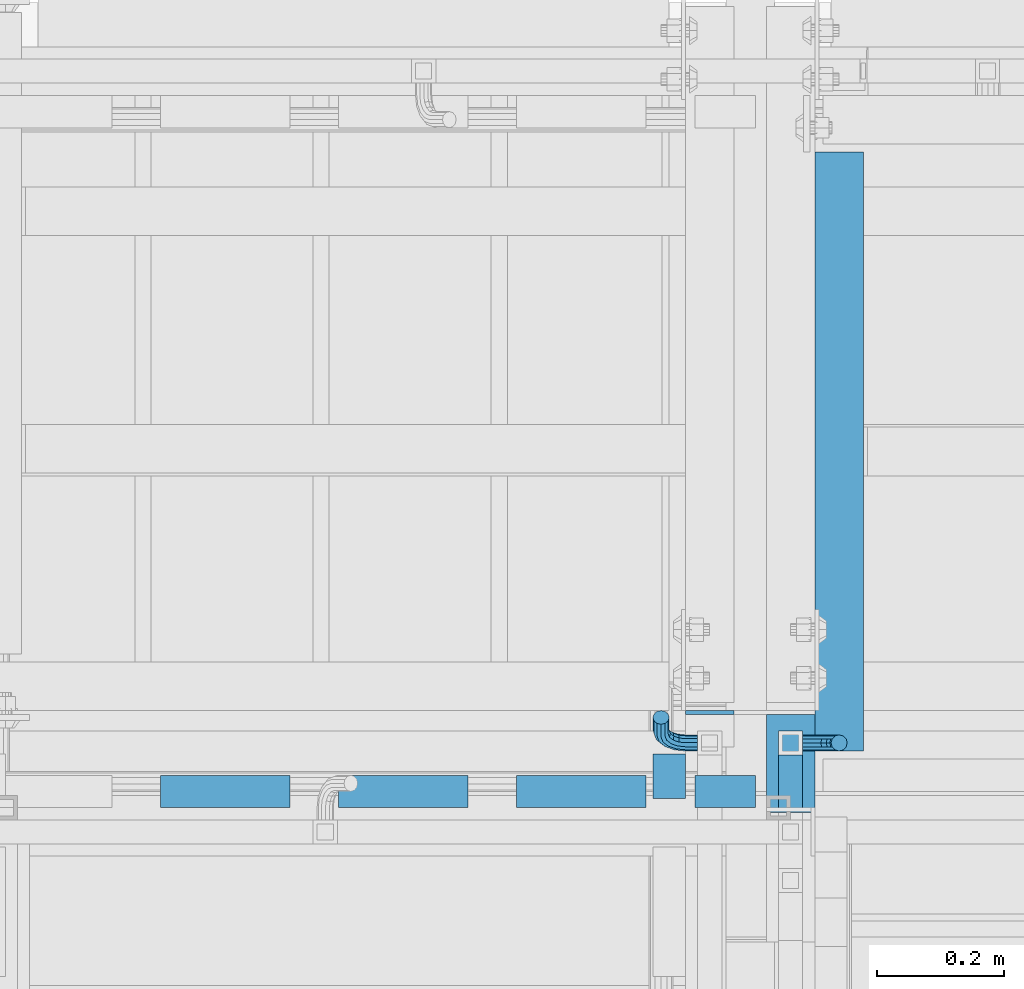
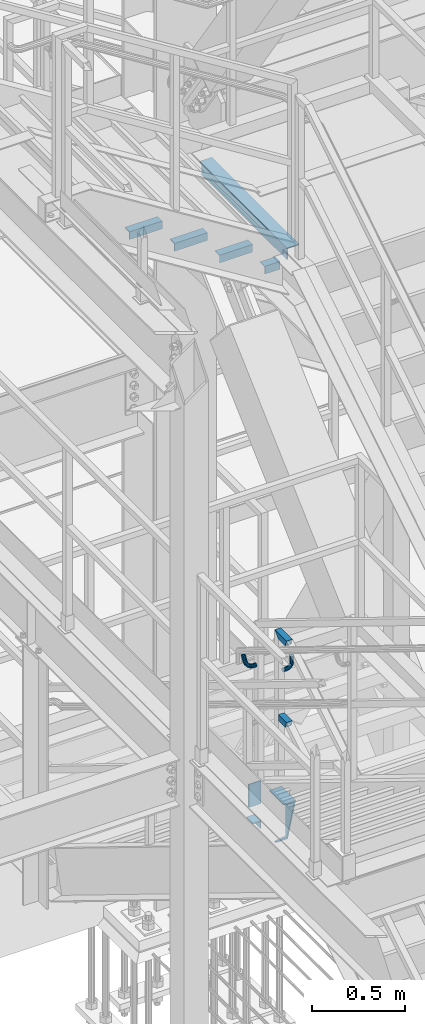
# One storey, part 2097 of 3843: 12 beams, 6 elements without a shape of their own.
"""IFC2X3 building model written with IfcOpenShell, lengths in millimetres."""

from ifc_helpers import new_model, si_unit, frame, origin_with_axes, place, context, subcontext, project, spatial, faceted_brep, material, type_object, element, aggregate, save


model = new_model("IFC2X3")

# Units and contexts
model_context = context("Model", 3, precision=1e-05, world=origin_with_axes())
body_context = subcontext(model_context, "Body", "Model", "MODEL_VIEW")
ifc_project = project(units=[si_unit("LENGTHUNIT", "METRE", prefix="MILLI"), si_unit("AREAUNIT", "SQUARE_METRE"), si_unit("VOLUMEUNIT", "CUBIC_METRE"), si_unit("MASSUNIT", "GRAM", prefix="KILO"), si_unit("TIMEUNIT", "SECOND"), si_unit("PLANEANGLEUNIT", "RADIAN"), si_unit("SOLIDANGLEUNIT", "STERADIAN"), si_unit("THERMODYNAMICTEMPERATUREUNIT", "DEGREE_CELSIUS"), si_unit("LUMINOUSINTENSITYUNIT", "LUMEN")], contexts=[model_context])

# Site, building, storey
site_placement = place(None, origin_with_axes())
site = spatial("IfcSite", under=ifc_project, at=site_placement, CompositionType="ELEMENT")
building_placement = place(site_placement, origin_with_axes())
building = spatial("IfcBuilding", under=site, at=building_placement, Name="Undefined", CompositionType="ELEMENT")
storey_placement = place(building_placement, origin_with_axes())
storey = spatial("IfcBuildingStorey", under=building, at=storey_placement, Name="Undefined", CompositionType="ELEMENT", Elevation=0.0)

# Assembly, beams
assembly_1_placement = place(storey_placement, origin_with_axes())
assembly_1 = element("IfcElementAssembly", 1, at=assembly_1_placement, inside=storey, Name="RAIL", AssemblyPlace="NOTDEFINED", PredefinedType="RIGID_FRAME")
ifc_material_1 = material()
beam_type_1 = type_object("IfcBeamType", Name="HSS1-1/2X1-1/2X1/4", PredefinedType="NOTDEFINED")
beam_1_placement = place(assembly_1_placement, frame((54444.9, 21755.1000004853, 33592.4769212995), z_axis=(0.0, 0.0, 1.0), x_axis=(0.0, 1.0, 0.0)))
beam_1 = element("IfcBeam", 2, at=beam_1_placement, type_object=beam_type_1, material=ifc_material_1, Name="RAIL", ObjectType="HSS1-1/2X1-1/2X1/4", context=body_context, shape_type="Brep", body=[
    faceted_brep([(3.59463564452017, 12.6999993300014, -12.6999993299978), (3.59463564452017, -12.6999993300014, -12.6999993299978), (82.5500000532629, -12.6999993300014, -12.6999993299978), (82.5500000532629, 12.6999993300014, -12.6999993299978), (-3.59463560431323, -12.6999993300014, 12.6999993299978), (82.5500000532629, -12.6999993300014, 12.6999993299978), (-3.59463560431323, 12.6999993300014, 12.6999993299978), (82.5500000532629, 12.6999993300014, 12.6999993299978), (5.39195352466777, 19.0499992350015, -19.0499992350015), (-5.39195348444628, 19.0499992350015, 19.0499992350015), (82.5500000532629, 19.0499992350015, 19.0499992350015), (82.5500000532629, 19.0499992350015, -19.0499992350015), (-5.39195348444628, -19.0499992350015, 19.0499992350015), (82.5500000532629, -19.0499999999993, 19.0499992350015), (5.39195352466777, -19.0499992350015, -19.0499992350015), (82.5500000532629, -19.0499992350015, -19.0499992350015)], [[[0, 1, 2, 3]], [[1, 4, 5, 2]], [[4, 6, 7, 5]], [[6, 0, 3, 7]], [[8, 9, 10, 11]], [[9, 12, 13, 10]], [[12, 14, 15, 13]], [[14, 8, 11, 15]], [[13, 15, 11, 10], [5, 7, 3, 2]], [[14, 12, 9, 8], [6, 4, 1, 0]]]),
])
beam_2_placement = place(assembly_1_placement, frame((54444.9, 21856.7000000145, 34125.8769212988), z_axis=(0.0, 0.0, -1.0), x_axis=(0.0, -1.0, 0.0)))
beam_2 = element("IfcBeam", 3, at=beam_2_placement, type_object=beam_type_1, material=ifc_material_1, Name="RAIL", ObjectType="HSS1-1/2X1-1/2X1/4", context=body_context, shape_type="Brep", body=[
    faceted_brep([(-12.6999993309546, 12.6999993299978, -12.6999993299978), (-12.6999993309546, -12.6999993299978, -12.6999993299978), (105.194632755753, -12.6999993299978, -12.6999993299978), (105.194632755753, 12.6999993299978, -12.6999993299978), (12.6999993290483, -12.6999993299978, 12.6999993299978), (98.0053615143879, -12.6999993299978, 12.6999993299978), (12.6999993290483, 12.6999993299978, 12.6999993299978), (98.0053615143879, 12.6999993299978, 12.6999993299978), (-19.0499992359546, 19.0499992350015, -19.0499992350015), (19.0499992350015, 19.0499992350015, 19.0499992350015), (96.2080436361175, 19.0499992350015, 19.0499992350015), (106.991950634023, 19.0499992350015, -19.0499992350015), (19.0499992350015, -19.0499992350015, 19.0499992350015), (96.2080436361175, -19.0499992350015, 19.0499992350015), (-19.0499992359546, -19.0499992350015, -19.0499992350015), (106.991950634023, -19.0499992350015, -19.0499992350015)], [[[0, 1, 2, 3]], [[1, 4, 5, 2]], [[4, 6, 7, 5]], [[6, 0, 3, 7]], [[8, 9, 10, 11]], [[9, 12, 13, 10]], [[12, 14, 15, 13]], [[14, 8, 11, 15]], [[13, 15, 11, 10], [5, 7, 3, 2]], [[14, 12, 9, 8], [6, 4, 1, 0]]]),
])

# Assembly, beam
assembly_2_placement = place(storey_placement, origin_with_axes())
assembly_2 = element("IfcElementAssembly", 4, at=assembly_2_placement, inside=storey, Name="STAIR", AssemblyPlace="NOTDEFINED", PredefinedType="RIGID_FRAME")
ifc_material_2 = material(Name="STEEL/A36")
beam_type_2 = type_object("IfcBeamType", PredefinedType="NOTDEFINED")
beam_3_placement = place(assembly_2_placement, frame((54317.9000000233, 21904.3250000033, 33164.6126284988), z_axis=(-1.0, 0.0, 0.0), x_axis=(0.0, 0.0, -1.0)))
beam_3 = element("IfcBeam", 5, at=beam_3_placement, type_object=beam_type_2, material=ifc_material_2, Name="PLATE", context=body_context, shape_type="Brep", body=[
    faceted_brep([(0.0, 3.17500000000291, -38.0999999999985), (0.0, 3.17500000000291, 38.0999999999985), (149.985707179992, 3.17499999999927, 38.0999999999985), (149.985707179992, 3.17499999999927, -38.0999999999985), (0.0, -3.17500000000291, 38.0999999999985), (149.985707179992, -3.17499999999927, 38.0999999999985), (0.0, -3.17500000000291, -38.0999999999985), (149.985707179992, -3.17499999999927, -38.0999999999985)], [[[0, 1, 2, 3]], [[1, 4, 5, 2]], [[4, 6, 7, 5]], [[6, 0, 3, 7]], [[5, 7, 3, 2]], [[6, 4, 1, 0]]]),
])

assembly_3_placement = place(storey_placement, origin_with_axes())
assembly_3 = element("IfcElementAssembly", 6, at=assembly_3_placement, inside=storey, Name="STAIR", AssemblyPlace="NOTDEFINED", PredefinedType="RIGID_FRAME")
beam_type_3 = type_object("IfcBeamType", Name="L2X2X3/16", PredefinedType="NOTDEFINED")
beam_4_placement = place(assembly_3_placement, frame((54389.8434500262, 21780.5000000956, 36618.3200647408), z_axis=(0.0, 1.0, 0.0), x_axis=(-1.0, 0.0, 0.0)))
beam_4 = element("IfcBeam", 7, at=beam_4_placement, type_object=beam_type_3, material=ifc_material_2, Name="ANGLE", ObjectType="L2X2X3/16", context=body_context, shape_type="Brep", body=[
    faceted_brep([(0.0, 25.4000000000015, -25.4000000000015), (0.0, 25.4000000000015, 25.4000000000015), (95.25, 25.4000000000015, 25.4000000000015), (95.25, 25.4000000000015, -25.4000000000015), (0.0, 20.6375000000007, 25.4000000000015), (95.25, 20.6374999999971, 25.4000000000015), (0.0, 20.6375000000007, -20.6375000000007), (95.25, 20.6374999999971, -20.6375000000007), (0.0, -25.4000000000015, -20.6375000000007), (95.25, -25.4000000000015, -20.6375000000007), (0.0, -25.4000000000015, -25.4000000000015), (95.25, -25.4000000000015, -25.4000000000015)], [[[0, 1, 2, 3]], [[1, 4, 5, 2]], [[4, 6, 7, 5]], [[6, 8, 9, 7]], [[8, 10, 11, 9]], [[10, 0, 3, 11]], [[5, 7, 9, 11, 3, 2]], [[10, 8, 6, 4, 1, 0]]]),
])

# Beam
beam_5_placement = place(assembly_2_placement, frame((54254.4000000118, 21839.6359969497, 32982.8769213407), z_axis=(-1.0, 0.0, 0.0), x_axis=(0.0, -1.0, 0.0)))
beam_5 = element("IfcBeam", 8, at=beam_5_placement, type_object=beam_type_3, material=ifc_material_2, Name="ANGLE", ObjectType="L2X2X3/16", context=body_context, shape_type="Brep", body=[
    faceted_brep([(0.0, 25.4000000000015, -25.4000000000015), (0.0, 25.4000000000015, 25.4000000000015), (69.8499999999985, 25.4000000000015, 25.4000000000015), (69.8499999999985, 25.4000000000015, -25.4000000000015), (0.0, 20.6375000000007, 25.4000000000015), (69.8499999999985, 20.6374999999971, 25.4000000000015), (0.0, 20.6375000000007, -20.6375000000007), (69.8499999999985, 20.6374999999971, -20.6374999999971), (0.0, -25.4000000000015, -20.6375000000007), (69.8499999999985, -25.4000000000015, -20.6374999999971), (0.0, -25.4000000000015, -25.4000000000015), (69.8499999999985, -25.4000000000015, -25.4000000000015)], [[[0, 1, 2, 3]], [[1, 4, 5, 2]], [[4, 6, 7, 5]], [[6, 8, 9, 7]], [[8, 10, 11, 9]], [[10, 0, 3, 11]], [[5, 7, 9, 11, 3, 2]], [[10, 8, 6, 4, 1, 0]]]),
])

aggregate(assembly_2, [beam_5, beam_3])

ifc_material_3 = material(Name="STEEL/A572-50")
beam_6_placement = place(assembly_3_placement, frame((53659.5934500424, 21780.5000000971, 37138.3983316133), z_axis=(0.0, 1.0, 0.0), x_axis=(-1.0, 0.0, 0.0)))
beam_6 = element("IfcBeam", 9, at=beam_6_placement, type_object=beam_type_3, material=ifc_material_3, Name="ANGLE", ObjectType="L2X2X3/16", context=body_context, shape_type="Brep", body=[
    faceted_brep([(0.0, 25.4000000000015, -25.4000000000015), (0.0, 25.4000000000015, 25.4000000000015), (203.199999999997, 25.4000000000015, 25.4000000000015), (203.199999999997, 25.4000000000015, -25.4000000000015), (0.0, 20.6375000000007, 25.4000000000015), (203.199999999997, 20.6375000000007, 25.4000000000015), (0.0, 20.6375000000007, -20.6375000000007), (203.199999999997, 20.6375000000007, -20.6375000000007), (0.0, -25.4000000000015, -20.6375000000007), (203.199999999997, -25.4000000000015, -20.6375000000007), (0.0, -25.4000000000015, -25.4000000000015), (203.199999999997, -25.4000000000015, -25.4000000000015)], [[[0, 1, 2, 3]], [[1, 4, 5, 2]], [[4, 6, 7, 5]], [[6, 8, 9, 7]], [[8, 10, 11, 9]], [[10, 0, 3, 11]], [[5, 7, 9, 11, 3, 2]], [[10, 8, 6, 4, 1, 0]]]),
])

beam_7_placement = place(assembly_3_placement, frame((53938.9934500395, 21780.5000000963, 36963.9849981713), z_axis=(0.0, 1.0, 0.0), x_axis=(-1.0, 0.0, 0.0)))
beam_7 = element("IfcBeam", 10, at=beam_7_placement, type_object=beam_type_3, material=ifc_material_3, Name="ANGLE", ObjectType="L2X2X3/16", context=body_context, shape_type="Brep", body=[
    faceted_brep([(0.0, 25.4000000000015, -25.4000000000015), (0.0, 25.4000000000015, 25.4000000000015), (203.199999999997, 25.4000000000015, 25.4000000000015), (203.199999999997, 25.4000000000015, -25.4000000000015), (0.0, 20.6375000000007, 25.4000000000015), (203.199999999997, 20.6375000000007, 25.4000000000015), (0.0, 20.6375000000007, -20.6375000000007), (203.199999999997, 20.6375000000007, -20.6375000000007), (0.0, -25.4000000000015, -20.6375000000007), (203.199999999997, -25.4000000000015, -20.6375000000007), (0.0, -25.4000000000015, -25.4000000000015), (203.199999999997, -25.4000000000015, -25.4000000000015)], [[[0, 1, 2, 3]], [[1, 4, 5, 2]], [[4, 6, 7, 5]], [[6, 8, 9, 7]], [[8, 10, 11, 9]], [[10, 0, 3, 11]], [[5, 7, 9, 11, 3, 2]], [[10, 8, 6, 4, 1, 0]]]),
])

beam_8_placement = place(assembly_3_placement, frame((54218.3934500365, 21780.5000000956, 36789.5716647292), z_axis=(0.0, 1.0, 0.0), x_axis=(-1.0, 0.0, 0.0)))
beam_8 = element("IfcBeam", 11, at=beam_8_placement, type_object=beam_type_3, material=ifc_material_3, Name="ANGLE", ObjectType="L2X2X3/16", context=body_context, shape_type="Brep", body=[
    faceted_brep([(0.0, 25.4000000000015, -25.4000000000015), (0.0, 25.4000000000015, 25.4000000000015), (203.199999999997, 25.4000000000015, 25.4000000000015), (203.199999999997, 25.4000000000015, -25.4000000000015), (0.0, 20.6375000000007, 25.4000000000015), (203.199999999997, 20.6375000000007, 25.4000000000015), (0.0, 20.6375000000007, -20.6375000000007), (203.199999999997, 20.6375000000007, -20.6375000000007), (0.0, -25.4000000000015, -20.6375000000007), (203.199999999997, -25.4000000000015, -20.6375000000007), (0.0, -25.4000000000015, -25.4000000000015), (203.199999999997, -25.4000000000015, -25.4000000000015)], [[[0, 1, 2, 3]], [[1, 4, 5, 2]], [[4, 6, 7, 5]], [[6, 8, 9, 7]], [[8, 10, 11, 9]], [[10, 0, 3, 11]], [[5, 7, 9, 11, 3, 2]], [[10, 8, 6, 4, 1, 0]]]),
])

aggregate(assembly_3, [beam_4, beam_6, beam_7, beam_8])

# Assembly, beam
assembly_4_placement = place(storey_placement, origin_with_axes())
assembly_4 = element("IfcElementAssembly", 12, at=assembly_4_placement, inside=storey, Name="STAIR", AssemblyPlace="NOTDEFINED", PredefinedType="RIGID_FRAME")
beam_type_4 = type_object("IfcBeamType", Name="C12X20.7", PredefinedType="NOTDEFINED")
beam_9_placement = place(assembly_4_placement, frame((54444.8999999994, 21882.0999999987, 32932.0769213151), z_axis=(0.0, 0.0, 1.0), x_axis=(0.0, -1.0, 0.0)))
beam_9 = element("IfcBeam", 13, at=beam_9_placement, type_object=beam_type_4, material=ifc_material_2, Name="STAIR", ObjectType="C12X20.7", context=body_context, shape_type="Brep", body=[
    faceted_brep([(-19.0500000046486, -38.0999999999985, 152.399999999994), (-19.0500000046486, 38.0999999999985, 152.400000000001), (-19.0500000046486, 38.0999999999985, 82.55000000359), (-19.0500000046486, 30.1624999999985, 82.55000000359), (-19.0500000046486, 30.1624999999985, 134.674927499997), (-19.0500000046486, -38.0999999999985, 146.047460000002), (47.9180121945137, -38.0999999999985, -152.400000000001), (49.7160490268361, -38.0999999999985, -146.047460000002), (38.0999999987034, -38.0999999999985, -146.047460000002), (38.0999999987034, -38.0999999999985, -152.400000000001), (52.9349555290828, 30.1624999999985, -134.674927499997), (38.0999999987034, 30.1624999999985, -134.674927499997), (38.0999999987034, 30.1624999999985, 82.55000000359), (38.0999999987034, 38.0999999999985, 82.55000000359), (38.0999999987034, 38.0999999999985, -152.400000000001), (47.9180121945137, 38.0999999999985, -152.400000000001), (134.189271642204, -38.0999999999985, 152.400000000001), (132.391234809882, -38.0999999999985, 146.047460000002), (129.172328307635, 30.1624999999985, 134.674927499997), (134.189271642204, 38.0999999999985, 152.400000000001)], [[[0, 1, 2, 3, 4, 5]], [[6, 7, 8, 9]], [[7, 10, 11, 8]], [[12, 13, 14, 9, 8, 11]], [[15, 6, 9, 14]], [[16, 17, 18, 10, 7, 6, 15, 19]], [[17, 16, 0, 5]], [[18, 17, 5, 4]], [[12, 11, 10, 18, 4, 3]], [[13, 12, 3, 2]], [[19, 15, 14, 13, 2, 1]], [[16, 19, 1, 0]]]),
])
aggregate(assembly_4, [beam_9])

assembly_5_placement = place(storey_placement, origin_with_axes())
assembly_5 = element("IfcElementAssembly", 14, at=assembly_5_placement, inside=storey, Name="RAIL", AssemblyPlace="NOTDEFINED", PredefinedType="RIGID_FRAME")
beam_type_5 = type_object("IfcBeamType", PredefinedType="NOTDEFINED")
beam_10_placement = place(assembly_5_placement, frame((54298.85, 21856.6999999933, 33971.0516784335), z_axis=(0.0, 0.851658317082228, -0.524097425050598), x_axis=(-1.0, 0.0, 0.0)))
beam_10 = element("IfcBeam", 15, at=beam_10_placement, type_object=beam_type_5, material=ifc_material_2, Name="BRACKET ARM", context=body_context, shape_type="Brep", body=[
    faceted_brep([(0.0, -12.6999999999971, 0.0), (0.0, -10.9985226280696, -6.34999999999854), (19.0500015258731, -10.9985226280623, -6.34999999999854), (19.0500015258731, -12.6999999999971, -6.33008312433958e-10), (0.0, -6.35000000000582, -10.9985226280623), (19.0500015258731, -6.34999999999854, -10.9985226280623), (0.0, 0.0, -12.6999999999971), (19.0500015258731, 0.0, -12.6999999999971), (0.0, 6.35000000000582, -10.9985226280623), (19.0500015258731, 6.34999999999854, -10.9985226280623), (0.0, 10.9985226280696, -6.34999999999854), (19.0500015258731, 10.9985226280623, -6.34999999999854), (0.0, 12.6999999999971, 0.0), (19.0500015258731, 12.6999999999971, 0.0), (0.0, 10.9985226280696, 6.34999999999854), (19.0500015258731, 10.9985226280623, 6.34999999999854), (0.0, 6.35000000000582, 10.9985226280623), (19.0500015258731, 6.34999999999854, 10.9985226280623), (0.0, 0.0, 12.6999999999971), (19.0500015258731, 0.0, 12.6999999999971), (0.0, -6.35000000000582, 10.9985226280623), (19.0500015258731, -6.34999999999854, 10.9985226280623), (0.0, -10.9985226280696, 6.34999999999854), (19.0500015258731, -10.9985226280623, 6.34999999999854), (38.4903193060891, -8.8330803677236, -3.34694050252438e-10), (37.8391921052389, -7.26112024908798, 6.34999999974389), (36.0602795104642, -2.96644533684594, 10.9985226280041), (33.6302397149266, 2.90018969451194, 12.7000000002226), (31.2001999194181, 8.76682472604443, 10.9985226285644), (29.4212873247307, 13.061499638774, 6.35000000070431), (28.7701601240115, 14.6334597580644, 7.78527464717627e-10), (29.4212873248762, 13.0614996394288, -6.34999999929278), (31.2001999196509, 8.76682472718676, -10.9985226275603), (33.6302397151885, 2.90018969582889, -12.6999999997788), (36.0602795106824, -2.96644533571089, -10.9985226281206), (37.8391921053699, -7.26112024843314, -6.35000000026048), (53.7678987435793, 3.38210125690239, -6.3499999994383), (54.9710249311902, 2.17897506880399, 5.0931703299284e-10), (50.4808968708676, 6.66910312997061, -10.9985226273784), (45.9907688103704, 11.1592311906061, -12.6999999991458), (41.5006407498004, 15.6493592510378, -10.9985226270364), (38.213638876914, 18.9363611235749, -6.34999999884167), (37.0105126890558, 20.1394873109457, 1.20053300634027e-09), (38.2136388766667, 18.9363611228473, 6.35000000115542), (41.5006407493784, 15.6493592497718, 10.9985226290883), (45.9907688098756, 11.1592311891436, 12.7000000008557), (50.4808968704456, 6.66910312870459, 10.9985226287463), (53.7678987433319, 3.38210125617479, 6.35000000055879), (64.4111202489148, 19.3108078951118, -6.34999999821594), (65.9830803677178, 18.6596806939051, 1.77533365786076e-09), (60.1164453365491, 21.0897204901557, -10.9985226262725), (54.2498103051475, 23.5197602857806, -12.6999999981927), (48.3831752736587, 25.9498000811873, -10.9985226262434), (44.0885003610601, 27.7287126756128, -6.34999999817228), (42.516540241937, 28.3798398759754, 1.83354131877422e-09), (44.08850036074, 27.7287126747688, 6.35000000183209), (48.3831752731057, 25.9498000797321, 10.9985226298813), (54.2498103045073, 23.5197602840999, 12.7000000018088), (60.1164453359961, 21.0897204886933, 10.9985226298522), (64.4111202485947, 19.3108078942678, 6.35000000178115), (68.1485226282239, 38.0999984746086, -6.3499999967753), (69.8499999999913, 38.0999984741211, 2.92493496090174e-09), (63.500000000291, 38.0999984749651, -10.9985226249628), (57.1500000003434, 38.0999984750961, -12.6999999970722), (50.8000000002939, 38.0999984749651, -10.998522625312), (46.1514773720992, 38.0999984746086, -6.34999999737192), (44.4499999999971, 38.0999984741211, 2.58296495303512e-09), (46.1514773717645, 38.0999984736336, 6.35000000262517), (50.7999999996973, 38.0999984732771, 10.9985226308127), (57.1499999996449, 38.0999984731461, 12.700000002922), (63.4999999996944, 38.0999984732771, 10.9985226311619), (68.1485226278892, 38.0999984736336, 6.35000000322179), (68.1485226280638, 76.2000000002372, -6.34999999414867), (69.8499999999913, 76.199999999757, 5.84986992180347e-09), (63.5, 76.200000000601, -10.9985226222125), (57.1499999999942, 76.2000000007247, -12.6999999941472), (50.7999999999884, 76.200000000601, -10.9985226222125), (46.1514773719246, 76.2000000002372, -6.34999999414867), (44.4499999999971, 76.199999999757, 5.84986992180347e-09), (46.1514773719246, 76.1999999992695, 6.35000000584841), (50.7999999999884, 76.1999999989057, 10.9985226339122), (57.1499999999942, 76.199999998782, 12.700000005847), (63.5, 76.1999999989057, 10.9985226339122), (68.1485226280638, 76.1999999992695, 6.35000000584841)], [[[0, 1, 2, 3]], [[1, 4, 5, 2]], [[4, 6, 7, 5]], [[6, 8, 9, 7]], [[8, 10, 11, 9]], [[10, 12, 13, 11]], [[12, 14, 15, 13]], [[14, 16, 17, 15]], [[16, 18, 19, 17]], [[18, 20, 21, 19]], [[20, 22, 23, 21]], [[22, 0, 3, 23]], [[22, 20, 18, 16, 14, 12, 10, 8, 6, 4, 1, 0]], [[23, 3, 24, 25]], [[21, 23, 25, 26]], [[19, 21, 26, 27]], [[17, 19, 27, 28]], [[15, 17, 28, 29]], [[13, 15, 29, 30]], [[11, 13, 30, 31]], [[9, 11, 31, 32]], [[7, 9, 32, 33]], [[5, 7, 33, 34]], [[2, 5, 34, 35]], [[3, 2, 35, 24]], [[35, 36, 37, 24]], [[34, 38, 36, 35]], [[33, 39, 38, 34]], [[32, 40, 39, 33]], [[31, 41, 40, 32]], [[30, 42, 41, 31]], [[29, 43, 42, 30]], [[28, 44, 43, 29]], [[27, 45, 44, 28]], [[26, 46, 45, 27]], [[25, 47, 46, 26]], [[24, 37, 47, 25]], [[36, 48, 49, 37]], [[38, 50, 48, 36]], [[39, 51, 50, 38]], [[40, 52, 51, 39]], [[41, 53, 52, 40]], [[42, 54, 53, 41]], [[43, 55, 54, 42]], [[44, 56, 55, 43]], [[45, 57, 56, 44]], [[46, 58, 57, 45]], [[47, 59, 58, 46]], [[37, 49, 59, 47]], [[48, 60, 61, 49]], [[50, 62, 60, 48]], [[51, 63, 62, 50]], [[52, 64, 63, 51]], [[53, 65, 64, 52]], [[54, 66, 65, 53]], [[55, 67, 66, 54]], [[56, 68, 67, 55]], [[57, 69, 68, 56]], [[58, 70, 69, 57]], [[59, 71, 70, 58]], [[49, 61, 71, 59]], [[61, 60, 72, 73]], [[60, 62, 74, 72]], [[62, 63, 75, 74]], [[63, 64, 76, 75]], [[64, 65, 77, 76]], [[65, 66, 78, 77]], [[66, 67, 79, 78]], [[67, 68, 80, 79]], [[68, 69, 81, 80]], [[69, 70, 82, 81]], [[70, 71, 83, 82]], [[71, 61, 73, 83]], [[74, 75, 76, 77, 78, 79, 80, 81, 82, 83, 73, 72]]]),
])
aggregate(assembly_5, [beam_10])

# Beam
beam_11_placement = place(assembly_1_placement, frame((54463.95, 21856.7000000031, 33878.2344184348), z_axis=(0.0, -1.0, 0.0), x_axis=(1.0, 0.0, 0.0)))
beam_11 = element("IfcBeam", 16, at=beam_11_placement, type_object=beam_type_5, material=ifc_material_2, Name="BRACKET ARM", context=body_context, shape_type="Brep", body=[
    faceted_brep([(0.0, -12.6999999999971, 0.0), (0.0, -10.9985226280696, -6.34999999999854), (19.0500015258731, -10.9985226280623, -6.34999999999854), (19.0500015258731, -12.6999999999971, -6.33008312433958e-10), (0.0, -6.35000000000582, -10.9985226280623), (19.0500015258731, -6.34999999999854, -10.9985226280623), (0.0, 0.0, -12.6999999999971), (19.0500015258731, 0.0, -12.6999999999971), (0.0, 6.35000000000582, -10.9985226280623), (19.0500015258731, 6.34999999999854, -10.9985226280623), (0.0, 10.9985226280696, -6.34999999999854), (19.0500015258731, 10.9985226280623, -6.34999999999854), (0.0, 12.6999999999971, 0.0), (19.0500015258731, 12.6999999999971, 0.0), (0.0, 10.9985226280696, 6.34999999999854), (19.0500015258731, 10.9985226280623, 6.34999999999854), (0.0, 6.35000000000582, 10.9985226280623), (19.0500015258731, 6.34999999999854, 10.9985226280623), (0.0, 0.0, 12.6999999999971), (19.0500015258731, 0.0, 12.6999999999971), (0.0, -6.35000000000582, 10.9985226280623), (19.0500015258731, -6.34999999999854, 10.9985226280623), (0.0, -10.9985226280696, 6.34999999999854), (19.0500015258731, -10.9985226280623, 6.34999999999854), (38.4903193060891, -8.8330803677236, -3.34694050252438e-10), (37.8391921052389, -7.26112024908798, 6.34999999974389), (36.0602795104642, -2.96644533684594, 10.9985226280041), (33.6302397149266, 2.90018969451194, 12.7000000002226), (31.2001999194181, 8.76682472604443, 10.9985226285644), (29.4212873247307, 13.061499638774, 6.35000000070431), (28.7701601240115, 14.6334597580644, 7.78527464717627e-10), (29.4212873248762, 13.0614996394288, -6.34999999929278), (31.2001999196509, 8.76682472718676, -10.9985226275603), (33.6302397151885, 2.90018969582889, -12.6999999997788), (36.0602795106824, -2.96644533571089, -10.9985226281206), (37.8391921053699, -7.26112024843314, -6.35000000026048), (53.7678987435793, 3.38210125690239, -6.3499999994383), (54.9710249311902, 2.17897506880399, 5.0931703299284e-10), (50.4808968708676, 6.66910312997061, -10.9985226273784), (45.9907688103704, 11.1592311906061, -12.6999999991458), (41.5006407498004, 15.6493592510378, -10.9985226270364), (38.213638876914, 18.9363611235749, -6.34999999884167), (37.0105126890558, 20.1394873109457, 1.20053300634027e-09), (38.2136388766667, 18.9363611228473, 6.35000000115542), (41.5006407493784, 15.6493592497718, 10.9985226290883), (45.9907688098756, 11.1592311891436, 12.7000000008557), (50.4808968704456, 6.66910312870459, 10.9985226287463), (53.7678987433319, 3.38210125617479, 6.35000000055879), (64.4111202489148, 19.3108078951118, -6.34999999821594), (65.9830803677178, 18.6596806939051, 1.77533365786076e-09), (60.1164453365491, 21.0897204901557, -10.9985226262725), (54.2498103051475, 23.5197602857806, -12.6999999981927), (48.3831752736587, 25.9498000811873, -10.9985226262434), (44.0885003610601, 27.7287126756128, -6.34999999817228), (42.516540241937, 28.3798398759754, 1.83354131877422e-09), (44.08850036074, 27.7287126747688, 6.35000000183209), (48.3831752731057, 25.9498000797321, 10.9985226298813), (54.2498103045073, 23.5197602840999, 12.7000000018088), (60.1164453359961, 21.0897204886933, 10.9985226298522), (64.4111202485947, 19.3108078942678, 6.35000000178115), (68.1485226282239, 38.0999984746086, -6.3499999967753), (69.8499999999913, 38.0999984741211, 2.92493496090174e-09), (63.500000000291, 38.0999984749651, -10.9985226249628), (57.1500000003434, 38.0999984750961, -12.6999999970722), (50.8000000002939, 38.0999984749651, -10.998522625312), (46.1514773720992, 38.0999984746086, -6.34999999737192), (44.4499999999971, 38.0999984741211, 2.58296495303512e-09), (46.1514773717645, 38.0999984736336, 6.35000000262517), (50.7999999996973, 38.0999984732771, 10.9985226308127), (57.1499999996449, 38.0999984731461, 12.700000002922), (63.4999999996944, 38.0999984732771, 10.9985226311619), (68.1485226278892, 38.0999984736336, 6.35000000322179), (68.1485226280638, 76.2000000002372, -6.34999999414867), (69.8499999999913, 76.199999999757, 5.84986992180347e-09), (63.5, 76.200000000601, -10.9985226222125), (57.1499999999942, 76.2000000007247, -12.6999999941472), (50.7999999999884, 76.200000000601, -10.9985226222125), (46.1514773719246, 76.2000000002372, -6.34999999414867), (44.4499999999971, 76.199999999757, 5.84986992180347e-09), (46.1514773719246, 76.1999999992695, 6.35000000584841), (50.7999999999884, 76.1999999989057, 10.9985226339122), (57.1499999999942, 76.199999998782, 12.700000005847), (63.5, 76.1999999989057, 10.9985226339122), (68.1485226280638, 76.1999999992695, 6.35000000584841)], [[[0, 1, 2, 3]], [[1, 4, 5, 2]], [[4, 6, 7, 5]], [[6, 8, 9, 7]], [[8, 10, 11, 9]], [[10, 12, 13, 11]], [[12, 14, 15, 13]], [[14, 16, 17, 15]], [[16, 18, 19, 17]], [[18, 20, 21, 19]], [[20, 22, 23, 21]], [[22, 0, 3, 23]], [[22, 20, 18, 16, 14, 12, 10, 8, 6, 4, 1, 0]], [[23, 3, 24, 25]], [[21, 23, 25, 26]], [[19, 21, 26, 27]], [[17, 19, 27, 28]], [[15, 17, 28, 29]], [[13, 15, 29, 30]], [[11, 13, 30, 31]], [[9, 11, 31, 32]], [[7, 9, 32, 33]], [[5, 7, 33, 34]], [[2, 5, 34, 35]], [[3, 2, 35, 24]], [[35, 36, 37, 24]], [[34, 38, 36, 35]], [[33, 39, 38, 34]], [[32, 40, 39, 33]], [[31, 41, 40, 32]], [[30, 42, 41, 31]], [[29, 43, 42, 30]], [[28, 44, 43, 29]], [[27, 45, 44, 28]], [[26, 46, 45, 27]], [[25, 47, 46, 26]], [[24, 37, 47, 25]], [[36, 48, 49, 37]], [[38, 50, 48, 36]], [[39, 51, 50, 38]], [[40, 52, 51, 39]], [[41, 53, 52, 40]], [[42, 54, 53, 41]], [[43, 55, 54, 42]], [[44, 56, 55, 43]], [[45, 57, 56, 44]], [[46, 58, 57, 45]], [[47, 59, 58, 46]], [[37, 49, 59, 47]], [[48, 60, 61, 49]], [[50, 62, 60, 48]], [[51, 63, 62, 50]], [[52, 64, 63, 51]], [[53, 65, 64, 52]], [[54, 66, 65, 53]], [[55, 67, 66, 54]], [[56, 68, 67, 55]], [[57, 69, 68, 56]], [[58, 70, 69, 57]], [[59, 71, 70, 58]], [[49, 61, 71, 59]], [[61, 60, 72, 73]], [[60, 62, 74, 72]], [[62, 63, 75, 74]], [[63, 64, 76, 75]], [[64, 65, 77, 76]], [[65, 66, 78, 77]], [[66, 67, 79, 78]], [[67, 68, 80, 79]], [[68, 69, 81, 80]], [[69, 70, 82, 81]], [[70, 71, 83, 82]], [[71, 61, 73, 83]], [[74, 75, 76, 77, 78, 79, 80, 81, 82, 83, 73, 72]]]),
])

aggregate(assembly_1, [beam_11, beam_1, beam_2])

# Assembly, beam
assembly_6_placement = place(storey_placement, origin_with_axes())
assembly_6 = element("IfcElementAssembly", 17, at=assembly_6_placement, inside=storey, Name="STAIR", AssemblyPlace="NOTDEFINED", PredefinedType="RIGID_FRAME")
beam_type_6 = type_object("IfcBeamType", Name="L3X3X1/4", PredefinedType="NOTDEFINED")
beam_12_placement = place(assembly_6_placement, frame((54521.1000000018, 21843.9999999999, 36605.6333313878), z_axis=(1.0, 0.0, 0.0), x_axis=(0.0, 1.0, 0.0)))
beam_12 = element("IfcBeam", 18, at=beam_12_placement, type_object=beam_type_6, material=ifc_material_2, Name="ANGLE", ObjectType="L3X3X1/4", context=body_context, shape_type="Brep", body=[
    faceted_brep([(914.399999920861, -38.0999999999985, -31.75), (914.399999920861, -38.0999999999985, -38.0999999999985), (914.399999892128, 31.7499999829597, -38.0999999999985), (914.399999892128, 31.75, -31.75), (939.799999962997, 31.75, -31.75), (939.799999962997, 31.7500000838336, -38.0999999999985), (0.0, 31.75, -31.75), (0.0, -38.0999999999985, -31.75), (0.0, -38.0999999999985, -38.0999999999985), (0.0, 38.0999999999985, -38.0999999999985), (939.800000000141, 38.0999999999985, -38.0999999999985), (0.0, 38.0999999999985, 38.0999999999985), (939.799999962997, 38.0999999999985, 38.0999999999985), (0.0, 31.75, 38.0999999999985), (914.399999892128, 31.75, 38.0999999999985), (939.799999962997, 31.75, 38.0999999999985)], [[[0, 1, 2, 3]], [[4, 3, 2, 5]], [[6, 7, 0, 3]], [[7, 8, 1, 0]], [[1, 8, 9, 10, 5, 2]], [[9, 11, 12, 10]], [[8, 7, 6, 13, 11, 9]], [[11, 13, 14, 15, 12]], [[10, 12, 15, 4, 5]], [[14, 13, 6, 3, 4, 15]]]),
])
aggregate(assembly_6, [beam_12])

save(model, "model.ifc")
